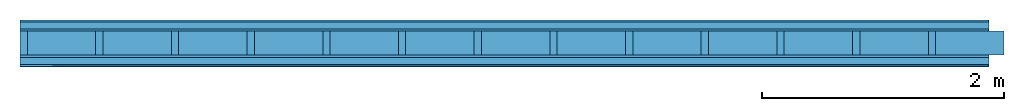
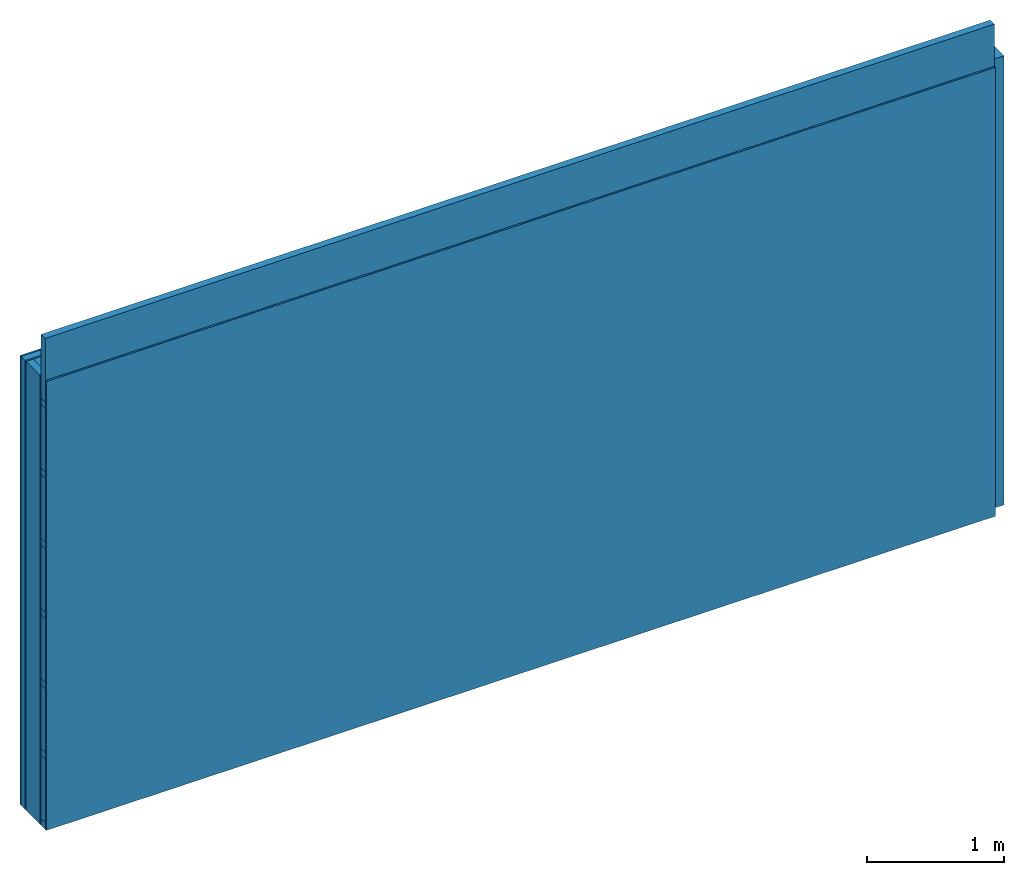
# One storey: 5 plates, 4 members, 1 element without a shape of its own.
"""IFC4 building model written with IfcOpenShell, lengths in metres."""

from ifc_helpers import new_model, si_unit, derived_unit, direction, frame, frame_2d, origin, origin_with_axes, place, context, project, spatial, rectangle, extrude, material, layer, layer_set, type_object, element, aggregate, save


model = new_model("IFC4")

# Units and contexts
plan_context = context("Plan", 3, precision=1e-05, world=origin(), true_north=direction((0.0, 1.0)))
model_context = context("Model", 3, precision=1e-05, world=origin(), true_north=direction((0.0, 1.0)))
ifc_project = project(units=[si_unit("LENGTHUNIT", "METRE"), derived_unit("SOUNDPRESSUREUNIT", [(si_unit("PRESSUREUNIT", "PASCAL", prefix="MICRO"), 0)]), si_unit("ENERGYUNIT", "JOULE", prefix="MEGA"), si_unit("MASSUNIT", "GRAM", prefix="KILO"), derived_unit("THERMALTRANSMITTANCEUNIT", [(si_unit("POWERUNIT", "WATT"), 1), (si_unit("AREAUNIT", "SQUARE_METRE"), -1), (si_unit("THERMODYNAMICTEMPERATUREUNIT", "KELVIN"), -1)]), derived_unit("AREADENSITYUNIT", [(si_unit("MASSUNIT", "GRAM", prefix="KILO"), 1), (si_unit("AREAUNIT", "SQUARE_METRE"), -1)]), derived_unit("USERDEFINED", [(si_unit("ENERGYUNIT", "JOULE", prefix="MEGA"), 1), (si_unit("AREAUNIT", "SQUARE_METRE"), -1)])], contexts=[plan_context, model_context])

# Site, building, storey
site = spatial("IfcSite", under=ifc_project)
building_placement = place(None, origin())
building = spatial("IfcBuilding", under=site, at=building_placement)
storey_placement = place(building_placement, origin())
storey = spatial("IfcBuildingStorey", under=building, at=storey_placement)

# Wall, members, plates
ifc_material_1 = material(Category="04.011")
ifc_layer_1 = layer(ifc_material_1, 0.015, Name="Surface 1")
ifc_material_2 = material(Category="10.008")
ifc_layer_2 = layer(ifc_material_2, 0.06, Name="outside 2nd layer")
ifc_material_3 = material(Category="03.007")
ifc_layer_3 = layer(ifc_material_3, 0.015, Name="outside 1st layer")
ifc_material_4 = material(Name="of the art")
ifc_layer_4 = layer(ifc_material_4, 0.0, Name="Bond")
ifc_layer_5 = layer(None, 0.2, Name="Support")
ifc_layer_6 = layer(ifc_material_4, 0.0, Name="Bond")
ifc_material_5 = material(Category="07.013")
ifc_layer_7 = layer(ifc_material_5, 0.019, Name="1st layer")
ifc_layer_8 = layer(None, 0.06, Name="Battens / profiles")
ifc_layer_9 = layer(ifc_material_3, 0.015, Name="Covering 1st layer")
ifc_material_6 = material(Name="Glued joints")
ifc_layer_10 = layer(ifc_material_6, 0.0, Name="Surface")
ifc_layer_set = layer_set([ifc_layer_1, ifc_layer_2, ifc_layer_3, ifc_layer_4, ifc_layer_5, ifc_layer_6, ifc_layer_7, ifc_layer_8, ifc_layer_9, ifc_layer_10])
wall_type = type_object("IfcWallType", Name="D0559", PredefinedType="NOTDEFINED", material=ifc_layer_set)
wall_placement = place(None, frame((0.0, 0.0, 0.0), z_axis=(0.0, -1.0, 0.0), x_axis=(1.0, 0.0, 0.0)))
wall = element("IfcWall", 1, at=wall_placement, inside=storey, type_object=wall_type, material=ifc_layer_set, Name="Wall #1")
ifc_material_7 = material()
member_1_placement = place(wall_placement, origin())
member_1 = element("IfcMember", 2, at=member_1_placement, material=ifc_material_7, Name="Support", context=plan_context, shape_type="SweptSolid", body=[
    extrude(rectangle(XDim=0.06, YDim=0.2, at=frame_2d((0.03, 0.1), x_axis=(1.0, 0.0))), frame((0.0, 4.0, 0.09), z_axis=(0.0, -1.0, 0.0), x_axis=(1.0, 0.0, 0.0)), (0.0, 0.0, 1.0), 4.0),
    extrude(rectangle(XDim=0.06, YDim=0.2, at=frame_2d((0.03, 0.1), x_axis=(1.0, 0.0))), frame((0.625, 4.0, 0.09), z_axis=(0.0, -1.0, 0.0), x_axis=(1.0, 0.0, 0.0)), (0.0, 0.0, 1.0), 4.0),
    extrude(rectangle(XDim=0.06, YDim=0.2, at=frame_2d((0.03, 0.1), x_axis=(1.0, 0.0))), frame((1.25, 4.0, 0.09), z_axis=(0.0, -1.0, 0.0), x_axis=(1.0, 0.0, 0.0)), (0.0, 0.0, 1.0), 4.0),
    extrude(rectangle(XDim=0.06, YDim=0.2, at=frame_2d((0.03, 0.1), x_axis=(1.0, 0.0))), frame((1.875, 4.0, 0.09), z_axis=(0.0, -1.0, 0.0), x_axis=(1.0, 0.0, 0.0)), (0.0, 0.0, 1.0), 4.0),
    extrude(rectangle(XDim=0.06, YDim=0.2, at=frame_2d((0.03, 0.1), x_axis=(1.0, 0.0))), frame((2.5, 4.0, 0.09), z_axis=(0.0, -1.0, 0.0), x_axis=(1.0, 0.0, 0.0)), (0.0, 0.0, 1.0), 4.0),
    extrude(rectangle(XDim=0.06, YDim=0.2, at=frame_2d((0.03, 0.1), x_axis=(1.0, 0.0))), frame((3.125, 4.0, 0.09), z_axis=(0.0, -1.0, 0.0), x_axis=(1.0, 0.0, 0.0)), (0.0, 0.0, 1.0), 4.0),
    extrude(rectangle(XDim=0.06, YDim=0.2, at=frame_2d((0.03, 0.1), x_axis=(1.0, 0.0))), frame((3.75, 4.0, 0.09), z_axis=(0.0, -1.0, 0.0), x_axis=(1.0, 0.0, 0.0)), (0.0, 0.0, 1.0), 4.0),
    extrude(rectangle(XDim=0.06, YDim=0.2, at=frame_2d((0.03, 0.1), x_axis=(1.0, 0.0))), frame((4.375, 4.0, 0.09), z_axis=(0.0, -1.0, 0.0), x_axis=(1.0, 0.0, 0.0)), (0.0, 0.0, 1.0), 4.0),
    extrude(rectangle(XDim=0.06, YDim=0.2, at=frame_2d((0.03, 0.1), x_axis=(1.0, 0.0))), frame((5.0, 4.0, 0.09), z_axis=(0.0, -1.0, 0.0), x_axis=(1.0, 0.0, 0.0)), (0.0, 0.0, 1.0), 4.0),
    extrude(rectangle(XDim=0.06, YDim=0.2, at=frame_2d((0.03, 0.1), x_axis=(1.0, 0.0))), frame((5.625, 4.0, 0.09), z_axis=(0.0, -1.0, 0.0), x_axis=(1.0, 0.0, 0.0)), (0.0, 0.0, 1.0), 4.0),
    extrude(rectangle(XDim=0.06, YDim=0.2, at=frame_2d((0.03, 0.1), x_axis=(1.0, 0.0))), frame((6.25, 4.0, 0.09), z_axis=(0.0, -1.0, 0.0), x_axis=(1.0, 0.0, 0.0)), (0.0, 0.0, 1.0), 4.0),
    extrude(rectangle(XDim=0.06, YDim=0.2, at=frame_2d((0.03, 0.1), x_axis=(1.0, 0.0))), frame((6.875, 4.0, 0.09), z_axis=(0.0, -1.0, 0.0), x_axis=(1.0, 0.0, 0.0)), (0.0, 0.0, 1.0), 4.0),
    extrude(rectangle(XDim=0.06, YDim=0.2, at=frame_2d((0.03, 0.1), x_axis=(1.0, 0.0))), frame((7.5, 4.0, 0.09), z_axis=(0.0, -1.0, 0.0), x_axis=(1.0, 0.0, 0.0)), (0.0, 0.0, 1.0), 4.0),
])
ifc_material_8 = material()
member_2_placement = place(wall_placement, origin())
member_2 = element("IfcMember", 3, at=member_2_placement, material=ifc_material_8, Name="Cavity", context=plan_context, shape_type="SweptSolid", body=[
    extrude(rectangle(XDim=0.565, YDim=0.2, at=frame_2d((0.2825, 0.1), x_axis=(1.0, 0.0))), frame((0.06, 4.0, 0.09), z_axis=(0.0, -1.0, 0.0), x_axis=(1.0, 0.0, 0.0)), (0.0, 0.0, 1.0), 4.0),
    extrude(rectangle(XDim=0.565, YDim=0.2, at=frame_2d((0.2825, 0.1), x_axis=(1.0, 0.0))), frame((0.685, 4.0, 0.09), z_axis=(0.0, -1.0, 0.0), x_axis=(1.0, 0.0, 0.0)), (0.0, 0.0, 1.0), 4.0),
    extrude(rectangle(XDim=0.565, YDim=0.2, at=frame_2d((0.2825, 0.1), x_axis=(1.0, 0.0))), frame((1.31, 4.0, 0.09), z_axis=(0.0, -1.0, 0.0), x_axis=(1.0, 0.0, 0.0)), (0.0, 0.0, 1.0), 4.0),
    extrude(rectangle(XDim=0.565, YDim=0.2, at=frame_2d((0.2825, 0.1), x_axis=(1.0, 0.0))), frame((1.935, 4.0, 0.09), z_axis=(0.0, -1.0, 0.0), x_axis=(1.0, 0.0, 0.0)), (0.0, 0.0, 1.0), 4.0),
    extrude(rectangle(XDim=0.565, YDim=0.2, at=frame_2d((0.2825, 0.1), x_axis=(1.0, 0.0))), frame((2.56, 4.0, 0.09), z_axis=(0.0, -1.0, 0.0), x_axis=(1.0, 0.0, 0.0)), (0.0, 0.0, 1.0), 4.0),
    extrude(rectangle(XDim=0.565, YDim=0.2, at=frame_2d((0.2825, 0.1), x_axis=(1.0, 0.0))), frame((3.185, 4.0, 0.09), z_axis=(0.0, -1.0, 0.0), x_axis=(1.0, 0.0, 0.0)), (0.0, 0.0, 1.0), 4.0),
    extrude(rectangle(XDim=0.565, YDim=0.2, at=frame_2d((0.2825, 0.1), x_axis=(1.0, 0.0))), frame((3.81, 4.0, 0.09), z_axis=(0.0, -1.0, 0.0), x_axis=(1.0, 0.0, 0.0)), (0.0, 0.0, 1.0), 4.0),
    extrude(rectangle(XDim=0.565, YDim=0.2, at=frame_2d((0.2825, 0.1), x_axis=(1.0, 0.0))), frame((4.435, 4.0, 0.09), z_axis=(0.0, -1.0, 0.0), x_axis=(1.0, 0.0, 0.0)), (0.0, 0.0, 1.0), 4.0),
    extrude(rectangle(XDim=0.565, YDim=0.2, at=frame_2d((0.2825, 0.1), x_axis=(1.0, 0.0))), frame((5.06, 4.0, 0.09), z_axis=(0.0, -1.0, 0.0), x_axis=(1.0, 0.0, 0.0)), (0.0, 0.0, 1.0), 4.0),
    extrude(rectangle(XDim=0.565, YDim=0.2, at=frame_2d((0.2825, 0.1), x_axis=(1.0, 0.0))), frame((5.685, 4.0, 0.09), z_axis=(0.0, -1.0, 0.0), x_axis=(1.0, 0.0, 0.0)), (0.0, 0.0, 1.0), 4.0),
    extrude(rectangle(XDim=0.565, YDim=0.2, at=frame_2d((0.2825, 0.1), x_axis=(1.0, 0.0))), frame((6.31, 4.0, 0.09), z_axis=(0.0, -1.0, 0.0), x_axis=(1.0, 0.0, 0.0)), (0.0, 0.0, 1.0), 4.0),
    extrude(rectangle(XDim=0.565, YDim=0.2, at=frame_2d((0.2825, 0.1), x_axis=(1.0, 0.0))), frame((6.935, 4.0, 0.09), z_axis=(0.0, -1.0, 0.0), x_axis=(1.0, 0.0, 0.0)), (0.0, 0.0, 1.0), 4.0),
    extrude(rectangle(XDim=0.565, YDim=0.2, at=frame_2d((0.2825, 0.1), x_axis=(1.0, 0.0))), frame((7.56, 4.0, 0.09), z_axis=(0.0, -1.0, 0.0), x_axis=(1.0, 0.0, 0.0)), (0.0, 0.0, 1.0), 4.0),
])
ifc_material_9 = material()
member_3_placement = place(wall_placement, origin())
member_3 = element("IfcMember", 4, at=member_3_placement, material=ifc_material_9, Name="Battens / profiles", context=plan_context, shape_type="SweptSolid", body=[
    extrude(rectangle(XDim=0.06, YDim=0.06, at=frame_2d((0.03, 0.03), x_axis=(1.0, 0.0))), frame((0.0, 0.0, 0.309), z_axis=(1.0, 0.0, 0.0), x_axis=(0.0, 1.0, 0.0)), (0.0, 0.0, 1.0), 8.0),
    extrude(rectangle(XDim=0.06, YDim=0.06, at=frame_2d((0.03, 0.03), x_axis=(1.0, 0.0))), frame((0.0, 0.625, 0.309), z_axis=(1.0, 0.0, 0.0), x_axis=(0.0, 1.0, 0.0)), (0.0, 0.0, 1.0), 8.0),
    extrude(rectangle(XDim=0.06, YDim=0.06, at=frame_2d((0.03, 0.03), x_axis=(1.0, 0.0))), frame((0.0, 1.25, 0.309), z_axis=(1.0, 0.0, 0.0), x_axis=(0.0, 1.0, 0.0)), (0.0, 0.0, 1.0), 8.0),
    extrude(rectangle(XDim=0.06, YDim=0.06, at=frame_2d((0.03, 0.03), x_axis=(1.0, 0.0))), frame((0.0, 1.875, 0.309), z_axis=(1.0, 0.0, 0.0), x_axis=(0.0, 1.0, 0.0)), (0.0, 0.0, 1.0), 8.0),
    extrude(rectangle(XDim=0.06, YDim=0.06, at=frame_2d((0.03, 0.03), x_axis=(1.0, 0.0))), frame((0.0, 2.5, 0.309), z_axis=(1.0, 0.0, 0.0), x_axis=(0.0, 1.0, 0.0)), (0.0, 0.0, 1.0), 8.0),
    extrude(rectangle(XDim=0.06, YDim=0.06, at=frame_2d((0.03, 0.03), x_axis=(1.0, 0.0))), frame((0.0, 3.125, 0.309), z_axis=(1.0, 0.0, 0.0), x_axis=(0.0, 1.0, 0.0)), (0.0, 0.0, 1.0), 8.0),
    extrude(rectangle(XDim=0.06, YDim=0.06, at=frame_2d((0.03, 0.03), x_axis=(1.0, 0.0))), frame((0.0, 3.75, 0.309), z_axis=(1.0, 0.0, 0.0), x_axis=(0.0, 1.0, 0.0)), (0.0, 0.0, 1.0), 8.0),
])
member_4_placement = place(wall_placement, origin())
member_4 = element("IfcMember", 5, at=member_4_placement, material=ifc_material_8, Name="Cavity", context=plan_context, shape_type="SweptSolid", body=[
    extrude(rectangle(XDim=0.565, YDim=0.06, at=frame_2d((0.2825, 0.03), x_axis=(1.0, 0.0))), frame((0.0, 0.06, 0.309), z_axis=(1.0, 0.0, 0.0), x_axis=(0.0, 1.0, 0.0)), (0.0, 0.0, 1.0), 8.0),
    extrude(rectangle(XDim=0.565, YDim=0.06, at=frame_2d((0.2825, 0.03), x_axis=(1.0, 0.0))), frame((0.0, 0.685, 0.309), z_axis=(1.0, 0.0, 0.0), x_axis=(0.0, 1.0, 0.0)), (0.0, 0.0, 1.0), 8.0),
    extrude(rectangle(XDim=0.565, YDim=0.06, at=frame_2d((0.2825, 0.03), x_axis=(1.0, 0.0))), frame((0.0, 1.31, 0.309), z_axis=(1.0, 0.0, 0.0), x_axis=(0.0, 1.0, 0.0)), (0.0, 0.0, 1.0), 8.0),
    extrude(rectangle(XDim=0.565, YDim=0.06, at=frame_2d((0.2825, 0.03), x_axis=(1.0, 0.0))), frame((0.0, 1.935, 0.309), z_axis=(1.0, 0.0, 0.0), x_axis=(0.0, 1.0, 0.0)), (0.0, 0.0, 1.0), 8.0),
    extrude(rectangle(XDim=0.565, YDim=0.06, at=frame_2d((0.2825, 0.03), x_axis=(1.0, 0.0))), frame((0.0, 2.56, 0.309), z_axis=(1.0, 0.0, 0.0), x_axis=(0.0, 1.0, 0.0)), (0.0, 0.0, 1.0), 8.0),
    extrude(rectangle(XDim=0.565, YDim=0.06, at=frame_2d((0.2825, 0.03), x_axis=(1.0, 0.0))), frame((0.0, 3.185, 0.309), z_axis=(1.0, 0.0, 0.0), x_axis=(0.0, 1.0, 0.0)), (0.0, 0.0, 1.0), 8.0),
    extrude(rectangle(XDim=0.565, YDim=0.06, at=frame_2d((0.2825, 0.03), x_axis=(1.0, 0.0))), frame((0.0, 3.81, 0.309), z_axis=(1.0, 0.0, 0.0), x_axis=(0.0, 1.0, 0.0)), (0.0, 0.0, 1.0), 8.0),
])
plate_1_placement = place(wall_placement, origin())
plate_1 = element("IfcPlate", 6, at=plate_1_placement, material=ifc_material_1, Name="Surface 1", context=plan_context, shape_type="SweptSolid", body=[
    extrude(rectangle(XDim=8.0, YDim=4.0, at=frame_2d((4.0, 2.0), x_axis=(1.0, 0.0))), origin_with_axes(), (0.0, 0.0, 1.0), 0.015),
])
plate_2_placement = place(wall_placement, origin())
plate_2 = element("IfcPlate", 7, at=plate_2_placement, material=ifc_material_2, Name="outside 2nd layer", context=plan_context, shape_type="SweptSolid", body=[
    extrude(rectangle(XDim=8.0, YDim=4.0, at=frame_2d((4.0, 2.0), x_axis=(1.0, 0.0))), frame((0.0, 0.0, 0.015), z_axis=(0.0, 0.0, 1.0), x_axis=(1.0, 0.0, 0.0)), (0.0, 0.0, 1.0), 0.06),
])
plate_3_placement = place(wall_placement, origin())
plate_3 = element("IfcPlate", 8, at=plate_3_placement, material=ifc_material_3, Name="outside 1st layer", context=plan_context, shape_type="SweptSolid", body=[
    extrude(rectangle(XDim=8.0, YDim=4.0, at=frame_2d((4.0, 2.0), x_axis=(1.0, 0.0))), frame((0.0, 0.0, 0.075), z_axis=(0.0, 0.0, 1.0), x_axis=(1.0, 0.0, 0.0)), (0.0, 0.0, 1.0), 0.015),
])
plate_4_placement = place(wall_placement, origin())
plate_4 = element("IfcPlate", 9, at=plate_4_placement, material=ifc_material_5, Name="1st layer", context=plan_context, shape_type="SweptSolid", body=[
    extrude(rectangle(XDim=8.0, YDim=4.0, at=frame_2d((4.0, 2.0), x_axis=(1.0, 0.0))), frame((0.0, 0.0, 0.29), z_axis=(0.0, 0.0, 1.0), x_axis=(1.0, 0.0, 0.0)), (0.0, 0.0, 1.0), 0.019),
])
plate_5_placement = place(wall_placement, origin())
plate_5 = element("IfcPlate", 10, at=plate_5_placement, material=ifc_material_3, Name="Covering 1st layer", context=plan_context, shape_type="SweptSolid", body=[
    extrude(rectangle(XDim=8.0, YDim=4.0, at=frame_2d((4.0, 2.0), x_axis=(1.0, 0.0))), frame((0.0, 0.0, 0.369), z_axis=(0.0, 0.0, 1.0), x_axis=(1.0, 0.0, 0.0)), (0.0, 0.0, 1.0), 0.015),
])
aggregate(wall, [plate_1, plate_2, plate_3, member_1, member_2, plate_4, member_3, member_4, plate_5])

save(model, "model.ifc")
